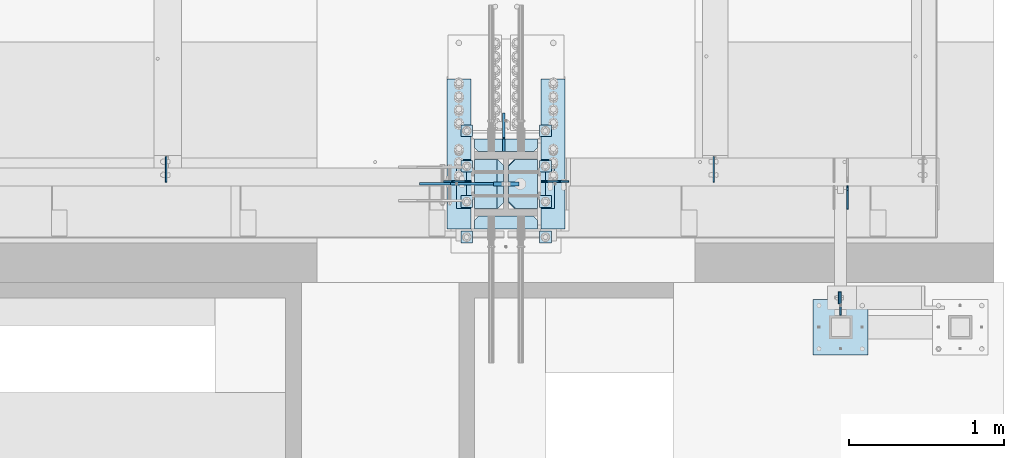
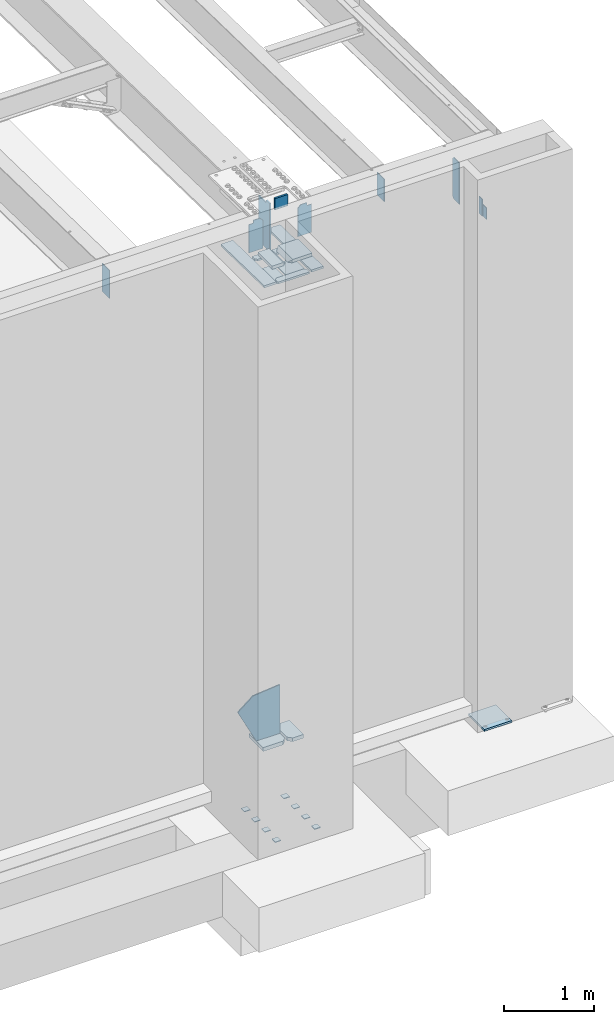
# One storey, part 1566 of 1763: 29 plates, 6 elements without a shape of their own.
"""IFC2X3 building model written with IfcOpenShell, lengths in millimetres."""

from ifc_helpers import new_model, si_unit, frame, origin_with_axes, place, context, subcontext, project, spatial, faceted_brep, material, type_object, element, aggregate, save


model = new_model("IFC2X3")

# Units and contexts
model_context = context("Model", 3, precision=1e-05, world=origin_with_axes())
body_context = subcontext(model_context, "Body", "Model", "MODEL_VIEW")
ifc_project = project(units=[si_unit("LENGTHUNIT", "METRE", prefix="MILLI"), si_unit("AREAUNIT", "SQUARE_METRE"), si_unit("VOLUMEUNIT", "CUBIC_METRE"), si_unit("MASSUNIT", "GRAM", prefix="KILO"), si_unit("TIMEUNIT", "SECOND"), si_unit("PLANEANGLEUNIT", "RADIAN"), si_unit("SOLIDANGLEUNIT", "STERADIAN"), si_unit("THERMODYNAMICTEMPERATUREUNIT", "DEGREE_CELSIUS"), si_unit("LUMINOUSINTENSITYUNIT", "LUMEN")], contexts=[model_context])

# Site, building, storey
site_placement = place(None, origin_with_axes())
site = spatial("IfcSite", under=ifc_project, at=site_placement, CompositionType="ELEMENT")
building_placement = place(site_placement, origin_with_axes())
building = spatial("IfcBuilding", under=site, at=building_placement, Name="Undefined", CompositionType="ELEMENT")
storey_placement = place(building_placement, origin_with_axes())
storey = spatial("IfcBuildingStorey", under=building, at=storey_placement, Name="Undefined", CompositionType="ELEMENT", Elevation=0.0)

# Assembly, plate
assembly_1_placement = place(storey_placement, origin_with_axes())
assembly_1 = element("IfcElementAssembly", 1, at=assembly_1_placement, inside=storey, Name="BEAM", AssemblyPlace="NOTDEFINED", PredefinedType="RIGID_FRAME")
ifc_material_1 = material(Name="STEEL/A36")
plate_type_1 = type_object("IfcPlateType", PredefinedType="NOTDEFINED")
plate_1_placement = place(assembly_1_placement, frame((-21878.3630581657, -14488.2432861204, 11817.35), z_axis=(0.0, 0.0, 1.0), x_axis=(0.0, 1.0, 0.0)))
plate_1 = element("IfcPlate", 2, at=plate_1_placement, type_object=plate_type_1, material=ifc_material_1, Name="PLATE", context=body_context, shape_type="Brep", body=[
    faceted_brep([(0.0, -4.76249999999982, 0.0), (-2.83762346953154e-10, -4.7624999996915, 228.600006103516), (-2.83762346953154e-10, 4.76250000028813, 228.600006103517), (0.0, 4.76249999999982, 0.0), (76.1999969480166, -4.76249999961874, 228.600006103516), (76.1999969480166, 4.76250000036089, 228.600006103517), (76.1999969482931, -4.76249999991705, 0.0), (76.1999969482931, 4.76250000006257, 1.81898940354586e-12)], [[[0, 1, 2, 3]], [[1, 4, 5, 2]], [[4, 6, 7, 5]], [[6, 0, 3, 7]], [[5, 7, 3, 2]], [[6, 4, 1, 0]]]),
])
aggregate(assembly_1, [plate_1])

# Assembly, plates
assembly_2_placement = place(storey_placement, origin_with_axes())
assembly_2 = element("IfcElementAssembly", 3, at=assembly_2_placement, inside=storey, Name="TEMPLATE", AssemblyPlace="NOTDEFINED", PredefinedType="RIGID_FRAME")
plate_2_placement = place(assembly_2_placement, frame((-24243.7372736984, -14020.8000000001, 3916.3625), z_axis=(-1.0, 0.0, 0.0), x_axis=(0.0, -1.0, 0.0)))
plate_2 = element("IfcPlate", 4, at=plate_2_placement, type_object=plate_type_1, material=ifc_material_1, Name="WASHER PLATE", context=body_context, shape_type="Brep", body=[
    faceted_brep([(0.0, -4.76249999999982, 0.0), (0.0, -4.76250000000073, 76.1999969482422), (0.0, 4.76250000000073, 76.1999969482422), (0.0, 4.76249999999982, 0.0), (76.1999969482422, -4.76249999999982, 76.1999969482422), (76.1999969482422, 4.76249999999982, 76.1999969482422), (76.1999969482931, -4.76249999991705, 0.0), (76.1999969482931, 4.76250000006257, 1.81898940354586e-12)], [[[0, 1, 2, 3]], [[1, 4, 5, 2]], [[4, 6, 7, 5]], [[6, 0, 3, 7]], [[5, 7, 3, 2]], [[6, 4, 1, 0]]]),
])
plate_3_placement = place(assembly_2_placement, frame((-23735.7372736984, -14020.8000000001, 3916.3625), z_axis=(-1.0, 0.0, 0.0), x_axis=(0.0, -1.0, 0.0)))
plate_3 = element("IfcPlate", 5, at=plate_3_placement, type_object=plate_type_1, material=ifc_material_1, Name="WASHER PLATE", context=body_context, shape_type="Brep", body=[
    faceted_brep([(0.0, -4.76249999999982, 0.0), (0.0, -4.76250000000073, 76.1999969482422), (0.0, 4.76250000000073, 76.1999969482422), (0.0, 4.76249999999982, 0.0), (76.1999969482422, -4.76249999999982, 76.1999969482422), (76.1999969482422, 4.76249999999982, 76.1999969482422), (76.1999969482931, -4.76249999991705, 0.0), (76.1999969482931, 4.76250000006257, 1.81898940354586e-12)], [[[0, 1, 2, 3]], [[1, 4, 5, 2]], [[4, 6, 7, 5]], [[6, 0, 3, 7]], [[5, 7, 3, 2]], [[6, 4, 1, 0]]]),
])
plate_4_placement = place(assembly_2_placement, frame((-24243.7372736984, -13792.2000000001, 3916.3625), z_axis=(-1.0, 0.0, 0.0), x_axis=(0.0, -1.0, 0.0)))
plate_4 = element("IfcPlate", 6, at=plate_4_placement, type_object=plate_type_1, material=ifc_material_1, Name="WASHER PLATE", context=body_context, shape_type="Brep", body=[
    faceted_brep([(0.0, -4.76249999999982, 0.0), (0.0, -4.76250000000073, 76.1999969482422), (0.0, 4.76250000000073, 76.1999969482422), (0.0, 4.76249999999982, 0.0), (76.1999969482422, -4.76249999999982, 76.1999969482422), (76.1999969482422, 4.76249999999982, 76.1999969482422), (76.1999969482931, -4.76249999991705, 0.0), (76.1999969482931, 4.76250000006257, 1.81898940354586e-12)], [[[0, 1, 2, 3]], [[1, 4, 5, 2]], [[4, 6, 7, 5]], [[6, 0, 3, 7]], [[5, 7, 3, 2]], [[6, 4, 1, 0]]]),
])
plate_5_placement = place(assembly_2_placement, frame((-23735.7372736984, -13792.2000000001, 3916.3625), z_axis=(-1.0, 0.0, 0.0), x_axis=(0.0, -1.0, 0.0)))
plate_5 = element("IfcPlate", 7, at=plate_5_placement, type_object=plate_type_1, material=ifc_material_1, Name="WASHER PLATE", context=body_context, shape_type="Brep", body=[
    faceted_brep([(0.0, -4.76249999999982, 0.0), (0.0, -4.76250000000073, 76.1999969482422), (0.0, 4.76250000000073, 76.1999969482422), (0.0, 4.76249999999982, 0.0), (76.1999969482422, -4.76249999999982, 76.1999969482422), (76.1999969482422, 4.76249999999982, 76.1999969482422), (76.1999969482931, -4.76249999991705, 0.0), (76.1999969482931, 4.76250000006257, 1.81898940354586e-12)], [[[0, 1, 2, 3]], [[1, 4, 5, 2]], [[4, 6, 7, 5]], [[6, 0, 3, 7]], [[5, 7, 3, 2]], [[6, 4, 1, 0]]]),
])
plate_6_placement = place(assembly_2_placement, frame((-24243.7372736984, -13563.6000000001, 3916.3625), z_axis=(-1.0, 0.0, 0.0), x_axis=(0.0, -1.0, 0.0)))
plate_6 = element("IfcPlate", 8, at=plate_6_placement, type_object=plate_type_1, material=ifc_material_1, Name="WASHER PLATE", context=body_context, shape_type="Brep", body=[
    faceted_brep([(0.0, -4.76249999999982, 0.0), (0.0, -4.76250000000073, 76.1999969482422), (0.0, 4.76250000000073, 76.1999969482422), (0.0, 4.76249999999982, 0.0), (76.1999969482422, -4.76249999999982, 76.1999969482422), (76.1999969482422, 4.76249999999982, 76.1999969482422), (76.1999969482931, -4.76249999991705, 0.0), (76.1999969482931, 4.76250000006257, 1.81898940354586e-12)], [[[0, 1, 2, 3]], [[1, 4, 5, 2]], [[4, 6, 7, 5]], [[6, 0, 3, 7]], [[5, 7, 3, 2]], [[6, 4, 1, 0]]]),
])
plate_7_placement = place(assembly_2_placement, frame((-23735.7372736984, -13563.6000000001, 3916.3625), z_axis=(-1.0, 0.0, 0.0), x_axis=(0.0, -1.0, 0.0)))
plate_7 = element("IfcPlate", 9, at=plate_7_placement, type_object=plate_type_1, material=ifc_material_1, Name="WASHER PLATE", context=body_context, shape_type="Brep", body=[
    faceted_brep([(0.0, -4.76249999999982, 0.0), (0.0, -4.76250000000073, 76.1999969482422), (0.0, 4.76250000000073, 76.1999969482422), (0.0, 4.76249999999982, 0.0), (76.1999969482422, -4.76249999999982, 76.1999969482422), (76.1999969482422, 4.76249999999982, 76.1999969482422), (76.1999969482931, -4.76249999991705, 0.0), (76.1999969482931, 4.76250000006257, 1.81898940354586e-12)], [[[0, 1, 2, 3]], [[1, 4, 5, 2]], [[4, 6, 7, 5]], [[6, 0, 3, 7]], [[5, 7, 3, 2]], [[6, 4, 1, 0]]]),
])
plate_8_placement = place(assembly_2_placement, frame((-24243.7372736984, -13335.0000000001, 3916.3625), z_axis=(-1.0, 0.0, 0.0), x_axis=(0.0, -1.0, 0.0)))
plate_8 = element("IfcPlate", 10, at=plate_8_placement, type_object=plate_type_1, material=ifc_material_1, Name="WASHER PLATE", context=body_context, shape_type="Brep", body=[
    faceted_brep([(0.0, -4.76249999999982, 0.0), (0.0, -4.76250000000073, 76.1999969482422), (0.0, 4.76250000000073, 76.1999969482422), (0.0, 4.76249999999982, 0.0), (76.1999969482422, -4.76249999999982, 76.1999969482422), (76.1999969482422, 4.76249999999982, 76.1999969482422), (76.1999969482931, -4.76249999991705, 0.0), (76.1999969482931, 4.76250000006257, 1.81898940354586e-12)], [[[0, 1, 2, 3]], [[1, 4, 5, 2]], [[4, 6, 7, 5]], [[6, 0, 3, 7]], [[5, 7, 3, 2]], [[6, 4, 1, 0]]]),
])
plate_9_placement = place(assembly_2_placement, frame((-23735.7372736984, -13335.0000000001, 3916.3625), z_axis=(-1.0, 0.0, 0.0), x_axis=(0.0, -1.0, 0.0)))
plate_9 = element("IfcPlate", 11, at=plate_9_placement, type_object=plate_type_1, material=ifc_material_1, Name="WASHER PLATE", context=body_context, shape_type="Brep", body=[
    faceted_brep([(0.0, -4.76249999999982, 0.0), (0.0, -4.76250000000073, 76.1999969482422), (0.0, 4.76250000000073, 76.1999969482422), (0.0, 4.76249999999982, 0.0), (76.1999969482422, -4.76249999999982, 76.1999969482422), (76.1999969482422, 4.76249999999982, 76.1999969482422), (76.1999969482931, -4.76249999991705, 0.0), (76.1999969482931, 4.76250000006257, 1.81898940354586e-12)], [[[0, 1, 2, 3]], [[1, 4, 5, 2]], [[4, 6, 7, 5]], [[6, 0, 3, 7]], [[5, 7, 3, 2]], [[6, 4, 1, 0]]]),
])
aggregate(assembly_2, [plate_2, plate_3, plate_4, plate_5, plate_6, plate_7, plate_8, plate_9])

# Assembly, plate
assembly_3_placement = place(storey_placement, origin_with_axes())
assembly_3 = element("IfcElementAssembly", 12, at=assembly_3_placement, inside=storey, Name="FRAME", AssemblyPlace="NOTDEFINED", PredefinedType="RIGID_FRAME")
plate_type_2 = type_object("IfcPlateType", PredefinedType="NOTDEFINED")
plate_10_placement = place(assembly_3_placement, frame((-21868.8380596657, -14412.0432891246, 11969.7500061035), z_axis=(0.0, 0.0, -1.0), x_axis=(0.0, -1.0, 0.0)))
plate_10 = element("IfcPlate", 13, at=plate_10_placement, type_object=plate_type_2, material=ifc_material_1, Name="PLATE", context=body_context, shape_type="Brep", body=[
    faceted_brep([(0.0, -4.76249999999982, 0.0), (-3.05175672110636e-06, -4.7625000002663, 152.399993896484), (-3.05175490211695e-06, 4.76249999972788, 152.399993896484), (0.0, 4.76249999999982, 0.0), (152.400009155272, -4.76249999975698, 152.399993896484), (152.400009155273, 4.76250000024447, 152.399993896484), (152.400009155272, -4.76249999948777, 5.45696821063757e-12), (152.400009155273, 4.76250000051368, 3.63797880709171e-12)], [[[0, 1, 2, 3]], [[1, 4, 5, 2]], [[4, 6, 7, 5]], [[6, 0, 3, 7]], [[5, 7, 3, 2]], [[6, 4, 1, 0]]]),
])

assembly_4_placement = place(storey_placement, origin_with_axes())
assembly_4 = element("IfcElementAssembly", 14, at=assembly_4_placement, inside=storey, Name="BEAM", AssemblyPlace="NOTDEFINED", PredefinedType="RIGID_FRAME")
plate_11_placement = place(assembly_4_placement, frame((-21824.388056465, -13880.3060686171, 11590.3375), z_axis=(0.0, 0.0, 1.0), x_axis=(0.0, 1.0, 0.0)))
plate_11 = element("IfcPlate", 15, at=plate_11_placement, type_object=plate_type_2, material=ifc_material_1, Name="PLATE", context=body_context, shape_type="Brep", body=[
    faceted_brep([(0.0, -4.76249999999982, 0.0), (0.0, -4.76250000012806, 568.325012206604), (0.0, 4.7624999999025, 568.325012206606), (0.0, 4.76249999999982, 0.0), (120.649993896484, -4.76250000000073, 568.325012207031), (120.649993896484, 4.76250000000073, 568.325012207031), (152.399993896484, -4.76250000000073, 536.575012207031), (152.399993896484, 4.76250000000073, 536.575012207031), (152.399993896484, -4.76250000000073, 31.75), (152.399993896484, 4.76250000000073, 31.75), (120.650001525879, -4.76249999999709, 0.0), (120.650001525879, 4.76249999999709, 0.0)], [[[0, 1, 2, 3]], [[1, 4, 5, 2]], [[4, 6, 7, 5]], [[6, 8, 9, 7]], [[8, 10, 11, 9]], [[10, 0, 3, 11]], [[5, 7, 9, 11, 3, 2]], [[10, 8, 6, 4, 1, 0]]]),
])

# Plate
plate_type_3 = type_object("IfcPlateType", PredefinedType="NOTDEFINED")
plate_12_placement = place(assembly_3_placement, frame((-22046.638056465, -14462.8432982799, 5080.0), z_axis=(1.0, 0.0, 0.0), x_axis=(0.0, -1.0, 0.0)))
plate_12 = element("IfcPlate", 16, at=plate_12_placement, type_object=plate_type_3, material=ifc_material_1, Name="PLATE", context=body_context, shape_type="Brep", body=[
    faceted_brep([(0.0, -12.6999999999971, -1.81898940354586e-12), (0.0, -12.6999999999998, 355.600006103516), (0.0, 12.6999999999998, 355.600006103516), (0.0, 12.6999999999971, -1.81898940354586e-12), (355.600006103516, -12.6999999999998, 355.600006103516), (355.600006103516, 12.6999999999998, 355.600006103516), (355.600006103516, -12.6999999999998, 0.0), (355.600006103516, 12.6999999999998, 0.0)], [[[0, 1, 2, 3]], [[1, 4, 5, 2]], [[4, 6, 7, 5]], [[6, 0, 3, 7]], [[5, 7, 3, 2]], [[6, 4, 1, 0]]]),
])

aggregate(assembly_3, [plate_10, plate_12])

# Assembly, plates
assembly_5_placement = place(storey_placement, origin_with_axes())
assembly_5 = element("IfcElementAssembly", 17, at=assembly_5_placement, inside=storey, Name="COLUMN", AssemblyPlace="NOTDEFINED", PredefinedType="RIGID_FRAME")
ifc_material_2 = material(Name="STEEL/A572-50")
plate_type_4 = type_object("IfcPlateType", PredefinedType="NOTDEFINED")
plate_13_placement = place(assembly_5_placement, frame((-23945.2872721785, -13715.9998186171, 12375.8598653502), z_axis=(0.0, 0.0, -1.0), x_axis=(-1.0, 0.0, 0.0)))
plate_13 = element("IfcPlate", 18, at=plate_13_placement, type_object=plate_type_4, material=ifc_material_2, Name="PLATE", context=body_context, shape_type="Brep", body=[
    faceted_brep([(0.0, 12.7, 152.399990844726), (-1.45519152283669e-11, 7.27595761418343e-12, 165.099990844727), (165.099990844727, 0.0, 165.099990844727), (165.099990844727, 12.7, 152.399990844726), (0.0, -12.7, 152.399990844726), (165.099990844727, -12.7, 152.399990844726), (0.0, 12.6999999999971, -1.81898940354586e-12), (0.0, -12.6999999999971, -1.81898940354586e-12), (165.099990844727, -12.7, 0.0), (165.099990844727, 12.7, 0.0)], [[[0, 1, 2, 3]], [[1, 4, 5, 2]], [[6, 7, 4, 1, 0]], [[5, 8, 9, 3, 2]], [[8, 7, 6, 9]], [[9, 6, 0, 3]], [[7, 8, 5, 4]]]),
])
plate_type_5 = type_object("IfcPlateType", PredefinedType="NOTDEFINED")
plate_14_placement = place(assembly_5_placement, frame((-24231.0372736984, -13874.7498293513, 11566.5250034926), z_axis=(0.0, 1.0, 0.0), x_axis=(1.0, 0.0, 0.0)))
plate_14 = element("IfcPlate", 19, at=plate_14_placement, type_object=plate_type_5, material=ifc_material_2, Name="PLATE", context=body_context, shape_type="Brep", body=[
    faceted_brep([(150.018745422363, 22.2249999999985, -1.45519152283669e-11), (188.118743896484, 22.2250000000222, 38.0999984741065), (150.018745422363, -15.8750547711388, 1.09139364212751e-11), (0.0, -22.2250000000022, 1.45519152283669e-11), (0.0, 22.2249999999985, -1.45519152283669e-11), (143.668767038595, -22.2250000000022, 1.45519152283669e-11), (0.0, -22.2249999997875, 317.500000000015), (143.668774023809, -22.2249999997875, 317.500000000015), (150.018745422363, 22.2250000002114, 317.499999999985), (0.0, 22.2250000002114, 317.499999999985), (150.018745422363, -15.8750617561036, 317.500000000011), (188.118743896484, 22.2250000001877, 279.400001525864)], [[[0, 1, 2]], [[3, 4, 0, 2, 5]], [[6, 3, 5, 7]], [[8, 9, 6, 7, 10]], [[8, 10, 11]], [[7, 5, 2, 1, 11, 10]], [[0, 4, 9, 8, 11, 1]], [[3, 6, 9, 4]]]),
])
plate_type_6 = type_object("IfcPlateType", PredefinedType="NOTDEFINED")
plate_15_placement = place(assembly_5_placement, frame((-24012.7560236984, -13874.7498293513, 11566.5250034926), z_axis=(0.0, 1.0, 0.0), x_axis=(1.0, 0.0, 0.0)))
plate_15 = element("IfcPlate", 20, at=plate_15_placement, type_object=plate_type_6, material=ifc_material_2, Name="PLATE", context=body_context, shape_type="Brep", body=[
    faceted_brep([(38.0999984741211, 22.2249999999985, -1.45519152283669e-11), (38.0999984741211, -15.8749712831541, 1.09139364212751e-11), (0.0, 22.2250000000222, 38.0999984741065), (296.068756103516, 22.2249999999985, -1.45519152283669e-11), (296.068756103516, -22.2250000000022, 1.45519152283669e-11), (44.4500271909674, -22.2250000000022, 1.45519152283669e-11), (296.068756103516, -22.2249999997875, 317.500000000015), (44.4500202057534, -22.2249999997875, 317.500000000015), (38.0999984741211, 22.2250000002114, 317.499999999985), (0.0, 22.2250000001877, 279.400001525864), (38.0999984741211, -15.8749782681552, 317.500000000011), (296.068756103516, 22.2250000002114, 317.499999999985)], [[[0, 1, 2]], [[0, 3, 4, 5, 1]], [[4, 6, 7, 5]], [[8, 9, 10]], [[6, 11, 8, 10, 7]], [[9, 2, 1, 5, 7, 10]], [[8, 11, 3, 0, 2, 9]], [[6, 4, 3, 11]]]),
])
plate_type_7 = type_object("IfcPlateType", PredefinedType="NOTDEFINED")
plate_16_placement = place(assembly_5_placement, frame((-24346.9247736984, -13874.749972618, 5054.60000349261), z_axis=(0.0, 1.0, 0.0), x_axis=(1.0, 0.0, 0.0)))
plate_16 = element("IfcPlate", 21, at=plate_16_placement, type_object=plate_type_7, material=ifc_material_1, Name="PLATE", context=body_context, shape_type="Brep", body=[
    faceted_brep([(0.0, -25.4000000000015, 0.0), (0.0, -25.4000000000751, 317.500000000018), (0.0, 25.3999999999251, 317.499999999984), (0.0, 25.4000000000015, 0.0), (257.968757629395, -25.4000000000751, 317.500000000018), (257.968757629395, 25.3999999999251, 317.499999999984), (304.006256103516, -25.4000000000642, 271.462501525897), (304.006256103516, 25.399999999936, 271.462501525863), (304.006256103516, -25.4000000000115, 46.0374984741393), (304.006256103516, 25.3999999999878, 46.0374984741047), (257.968757629395, -25.4000000000005, 1.81898940354586e-11), (257.968757629395, 25.3999999999987, -1.63709046319127e-11)], [[[0, 1, 2, 3]], [[1, 4, 5, 2]], [[4, 6, 7, 5]], [[6, 8, 9, 7]], [[8, 10, 11, 9]], [[10, 0, 3, 11]], [[5, 7, 9, 11, 3, 2]], [[10, 8, 6, 4, 1, 0]]]),
])
plate_type_8 = type_object("IfcPlateType", PredefinedType="NOTDEFINED")
plate_17_placement = place(assembly_5_placement, frame((-24012.7560236984, -13874.749972618, 5054.60000349261), z_axis=(0.0, 1.0, 0.0), x_axis=(1.0, 0.0, 0.0)))
plate_17 = element("IfcPlate", 22, at=plate_17_placement, type_object=plate_type_8, material=ifc_material_1, Name="PLATE", context=body_context, shape_type="Brep", body=[
    faceted_brep([(0.0, -25.4000000000115, 46.0374984741393), (0.0, -25.4000000000642, 271.462501525897), (0.0, 25.399999999936, 271.462501525863), (0.0, 25.3999999999878, 46.0374984741047), (46.0374984741211, -25.4000000000751, 317.500000000018), (46.0374984741211, 25.3999999999251, 317.499999999984), (188.118743896484, -25.4000000000751, 317.500000000018), (188.118743896484, 25.3999999999251, 317.499999999984), (188.118743896484, -25.4000000000005, 1.81898940354586e-11), (188.118743896484, 25.3999999999987, -1.63709046319127e-11), (46.0374984741211, -25.4000000000005, 1.81898940354586e-11), (46.0374984741211, 25.3999999999987, -1.63709046319127e-11)], [[[0, 1, 2, 3]], [[1, 4, 5, 2]], [[4, 6, 7, 5]], [[6, 8, 9, 7]], [[8, 10, 11, 9]], [[10, 0, 3, 11]], [[5, 7, 9, 11, 3, 2]], [[10, 8, 6, 4, 1, 0]]]),
])
ifc_material_3 = material(Name="STEEL/A572-GR.50")
plate_type_9 = type_object("IfcPlateType", PredefinedType="NOTDEFINED")
plate_18_placement = place(assembly_5_placement, frame((-24042.9185236223, -13715.9999990896, 5080.0), z_axis=(-1.0, 0.0, 0.0), x_axis=(0.0, 0.0, 1.0)))
plate_18 = element("IfcPlate", 23, at=plate_18_placement, type_object=plate_type_9, material=ifc_material_3, Name="PLATE", context=body_context, shape_type="Brep", body=[
    faceted_brep([(-7.27595761418343e-12, -7.9375, 0.0), (-1.96450855582952e-10, -7.9375, 304.799987792954), (-1.96450855582952e-10, 7.9375, 304.799987792954), (-7.27595761418343e-12, 7.9375, 0.0), (467.916351318356, -7.93750000005821, 542.637756347671), (467.916351318363, 7.93749999994179, 542.637756347649), (626.727233886716, -7.93749999988177, 344.407836914084), (626.727233886722, 7.93750000011823, 344.407836914059), (660.400024414061, -7.93749999969259, 1.81898940354586e-11), (660.400024414067, 7.93750000030741, -3.63797880709171e-12)], [[[0, 1, 2, 3]], [[1, 4, 5, 2]], [[4, 6, 7, 5]], [[6, 8, 9, 7]], [[8, 0, 3, 9]], [[5, 7, 9, 3, 2]], [[8, 6, 4, 1, 0]]]),
])
plate_type_10 = type_object("IfcPlateType", PredefinedType="NOTDEFINED")
plate_19_placement = place(assembly_5_placement, frame((-24043.7122736984, -13508.0373164194, 12153.8208949172), z_axis=(0.0, 1.0, 0.0), x_axis=(0.0, 0.0, -1.0)))
plate_19 = element("IfcPlate", 24, at=plate_19_placement, type_object=plate_type_10, material=ifc_material_2, Name="PLATE", context=body_context, shape_type="Brep", body=[
    faceted_brep([(652.461860656904, -7.9375, 250.824996880596), (652.461861279093, -7.9375, 95.2500331813098), (652.461861279093, 7.9375, 95.2500331813098), (652.461860656904, 7.9375, 250.824996947802), (653.428591221118, -7.9375, 90.3899536671306), (653.428591221118, 7.9375, 90.3899536671306), (656.181605138074, -7.9375, 86.2697772099873), (656.181605138074, 7.9375, 86.2697772099873), (660.301781617236, -7.9375, 83.5167633259862), (660.301781617236, 7.9375, 83.5167633259862), (665.16186113915, -7.9375, 82.5500334228345), (665.16186113915, 7.9375, 82.5500334228345), (701.674986078371, -7.9375, 82.5500335688612), (701.674987793023, 7.9375, 82.5500335688612), (36.5118331910835, -7.9375, 250.824996039873), (36.5118331910835, 7.9375, 250.824996948217), (36.5118305464439, 7.9375, 95.2500632755091), (36.5118305464439, -7.9375, 95.2500632755091), (35.5451005412397, 7.9375, 90.3899837738973), (35.5451005412397, -7.9375, 90.3899837738973), (32.7920865707219, 7.9375, 86.2698073525426), (32.7920865707219, -7.9375, 86.2698073525426), (28.6719100557711, 7.9375, 83.5167935221034), (28.6719100557711, -7.9375, 83.5167935221034), (23.8118305212902, 7.9375, 82.5500636821344), (23.8118305212902, -7.9375, 82.5500636821344), (5.27506927028298e-11, 7.9375, 82.5500640869141), (5.27506927028298e-11, -7.9375, 82.5500640869141), (-7.27595761418343e-12, 7.9375, 0.0), (-7.27595761418343e-12, -7.9375, 0.0), (701.674987792967, -7.9375, -4.74756234325469e-10), (701.674987792967, 7.9375, -4.74756234325469e-10)], [[[0, 1, 2, 3]], [[4, 5, 2, 1]], [[6, 7, 5, 4]], [[8, 9, 7, 6]], [[10, 11, 9, 8]], [[12, 13, 11, 10]], [[14, 15, 16, 17]], [[17, 16, 18, 19]], [[19, 18, 20, 21]], [[21, 20, 22, 23]], [[23, 22, 24, 25]], [[25, 24, 26, 27]], [[28, 29, 27, 26]], [[30, 29, 28, 31]], [[8, 6, 4, 1, 0, 14, 17, 19, 21, 23, 25, 27, 29, 30, 12, 10]], [[15, 14, 0, 3]], [[31, 28, 26, 24, 22, 20, 18, 16, 15, 3, 2, 5, 7, 9, 11, 13]], [[30, 31, 13, 12]]]),
])
plate_type_11 = type_object("IfcPlateType", PredefinedType="NOTDEFINED")
plate_20_placement = place(assembly_5_placement, frame((-24231.0372681234, -13508.0373327294, 11438.1830739405), z_axis=(1.0, 0.0, 0.0), x_axis=(0.0, 1.0, 0.0)))
plate_20 = element("IfcPlate", 25, at=plate_20_placement, type_object=plate_type_11, material=ifc_material_2, Name="PLATE", context=body_context, shape_type="Brep", body=[
    faceted_brep([(-2.63229335373174e-12, -12.7, 25.3999996185303), (-4.02906152885407e-09, -12.6999999999989, 380.999994277954), (-4.04725142288953e-09, 12.7000000000025, 380.999994277954), (-2.78305378742516e-10, 12.7000000000025, 25.3999996185303), (25.399999614232, -12.6999999999825, 406.399993896484), (25.3999996142138, 12.7000000000189, 406.399993896484), (82.5500030517669, -12.6999999999425, 406.399993896484), (82.5500030517469, 12.7000000000571, 406.399993896484), (82.5500030517669, -12.6999999999425, -4.36557456851006e-11), (82.5500030517469, 12.7000000000571, -4.36557456851006e-11), (25.3999996185303, -12.7, 0.0), (25.3999996185194, 12.7000000000189, -1.45519152283669e-11)], [[[0, 1, 2, 3]], [[1, 4, 5, 2]], [[4, 6, 7, 5]], [[6, 8, 9, 7]], [[8, 10, 11, 9]], [[10, 0, 3, 11]], [[5, 7, 9, 11, 3, 2]], [[10, 8, 6, 4, 1, 0]]]),
])
plate_21_placement = place(assembly_5_placement, frame((-24231.0372681234, -13923.9623312835, 11438.1830739405), z_axis=(1.0, 0.0, 0.0), x_axis=(0.0, -1.0, 0.0)))
plate_21 = element("IfcPlate", 26, at=plate_21_placement, type_object=plate_type_11, material=ifc_material_2, Name="PLATE", context=body_context, shape_type="Brep", body=[
    faceted_brep([(-2.63229335373174e-12, -12.7, 25.3999996185303), (-4.02906152885407e-09, -12.6999999999989, 380.999994277954), (-4.04725142288953e-09, 12.7000000000025, 380.999994277954), (-2.78305378742516e-10, 12.7000000000025, 25.3999996185303), (25.399999614232, -12.6999999999825, 406.399993896484), (25.3999996142138, 12.7000000000189, 406.399993896484), (82.5500030517669, -12.6999999999425, 406.399993896484), (82.5500030517469, 12.7000000000571, 406.399993896484), (82.5500030517669, -12.6999999999425, -4.36557456851006e-11), (82.5500030517469, 12.7000000000571, -4.36557456851006e-11), (25.3999996185303, -12.7, 0.0), (25.3999996185194, 12.7000000000189, -1.45519152283669e-11)], [[[0, 1, 2, 3]], [[1, 4, 5, 2]], [[4, 6, 7, 5]], [[6, 8, 9, 7]], [[8, 10, 11, 9]], [[10, 0, 3, 11]], [[5, 7, 9, 11, 3, 2]], [[10, 8, 6, 4, 1, 0]]]),
])
plate_type_12 = type_object("IfcPlateType", PredefinedType="NOTDEFINED")
plate_22_placement = place(assembly_5_placement, frame((-24253.2622732509, -13699.3310686168, 12158.6625004447), z_axis=(-1.0, 0.0, 0.0), x_axis=(0.0, 0.0, -1.0)))
plate_22 = element("IfcPlate", 27, at=plate_22_placement, type_object=plate_type_12, material=ifc_material_3, Name="PLATE", context=body_context, shape_type="Brep", body=[
    faceted_brep([(38.0999984741193, -4.76250000000073, -2.66707502305508e-07), (0.0, -4.76249999999709, 38.1000000000004), (0.0, 4.76249999999709, 38.1000000000004), (38.0999984741193, 4.76250000000073, 2.5465851649642e-11), (26.9875001903692, -4.76250000000073, 117.47502130835), (26.9875001903692, 4.76250000000073, 117.47502130835), (0.0, 4.76250000013351, 117.474999999919), (0.0, -4.76249999983884, 117.474999999904), (31.8475797103492, -4.76250000000073, 118.441751221213), (31.8475797103492, 4.76250000000073, 118.441751221213), (35.9677561840108, -4.76250000000073, 121.194765113451), (35.9677561840108, 4.76250000000073, 121.194765113451), (38.7207700927302, -4.76250000000073, 125.314941576096), (38.7207700927302, 4.76250000000073, 125.314941576096), (39.6875000250402, -4.76250000000073, 130.175021092207), (39.6875000250402, 4.76250000000073, 130.175021092207), (39.6875001203061, -4.76250000000073, 177.800003341534), (39.6875001203061, 4.76250000000073, 177.799987792991), (423.862487792872, -4.76250000000073, 177.799987793198), (423.862487792872, 4.76250000000073, 177.799987793198), (423.862487792967, -4.76250000000073, 2.3283064365387e-10), (423.862487792967, 4.76250000000073, 2.3283064365387e-10)], [[[0, 1, 2, 3]], [[4, 5, 6, 7]], [[8, 9, 5, 4]], [[10, 11, 9, 8]], [[12, 13, 11, 10]], [[14, 15, 13, 12]], [[16, 17, 15, 14]], [[18, 19, 17, 16]], [[18, 20, 21, 19]], [[21, 20, 0, 3]], [[6, 5, 9, 11, 13, 15, 17, 19, 21, 3, 2]], [[7, 6, 2, 1]], [[20, 18, 16, 14, 12, 10, 8, 4, 7, 1, 0]]]),
])
plate_23_placement = place(assembly_5_placement, frame((-23802.4122732509, -13699.3310686168, 12158.6624995558), z_axis=(1.0, 0.0, 0.0), x_axis=(0.0, 0.0, -1.0)))
plate_23 = element("IfcPlate", 28, at=plate_23_placement, type_object=plate_type_12, material=ifc_material_3, Name="PLATE", context=body_context, shape_type="Brep", body=[
    faceted_brep([(26.9875001903692, -4.76250000000073, 117.47502130835), (26.9875001903692, 4.76250000000073, 117.47502130835), (0.0, 4.76250000013351, 117.474999999919), (0.0, -4.76249999983884, 117.474999999904), (31.8475797103492, -4.76250000000073, 118.441751221213), (31.8475797103492, 4.76250000000073, 118.441751221213), (35.9677561840108, -4.76250000000073, 121.194765113451), (35.9677561840108, 4.76250000000073, 121.194765113451), (38.7207700927302, -4.76250000000073, 125.314941576096), (38.7207700927302, 4.76250000000073, 125.314941576096), (39.6875000250402, -4.76250000000073, 130.175021092207), (39.6875000250402, 4.76250000000073, 130.175021092207), (39.6875001203061, -4.76250000000073, 177.800003341534), (39.6875001203061, 4.76250000000073, 177.799987792991), (38.0999984741193, -4.76250000000073, -2.66707502305508e-07), (0.0, -4.76249999999709, 38.1000000000004), (0.0, 4.76249999999709, 38.1000000000004), (38.0999984741193, 4.76250000000073, 2.5465851649642e-11), (423.862487792967, 4.76250000000073, 2.3283064365387e-10), (423.862487792967, -4.76250000000073, 2.3283064365387e-10), (423.862487792872, -4.76250000000073, 177.799987793198), (423.862487792872, 4.76250000000073, 177.799987793198)], [[[0, 1, 2, 3]], [[4, 5, 1, 0]], [[6, 7, 5, 4]], [[8, 9, 7, 6]], [[10, 11, 9, 8]], [[12, 13, 11, 10]], [[14, 15, 16, 17]], [[18, 19, 14, 17]], [[20, 19, 18, 21]], [[19, 20, 12, 10, 8, 6, 4, 0, 3, 15, 14]], [[3, 2, 16, 15]], [[2, 1, 5, 7, 9, 11, 13, 21, 18, 17, 16]], [[20, 21, 13, 12]]]),
])
plate_type_13 = type_object("IfcPlateType", PredefinedType="NOTDEFINED")
plate_24_placement = place(assembly_5_placement, frame((-23646.8372737834, -13037.9263617301, 11429.9455920529), z_axis=(0.0, -0.999781542838788, 0.0209013539966307), x_axis=(-1.0, 0.0, 0.0)))
plate_24 = element("IfcPlate", 29, at=plate_24_placement, type_object=plate_type_13, material=ifc_material_2, Name="PLATE", context=body_context, shape_type="Brep", body=[
    faceted_brep([(0.0, -14.2875000000058, 0.0), (-5.78584149479866e-08, -14.2875000003296, 968.498901367962), (-5.78475010115653e-08, 14.2874999996911, 968.498901367973), (0.0, 14.2875000000058, 0.0), (155.574996949199, -14.2875000002678, 968.498901367961), (155.57499694921, 14.2874999997548, 968.498901367971), (155.574996948242, -14.2874999999494, -2.16459739021957e-10), (155.574996948249, 14.2875000000731, -2.07364792004228e-10)], [[[0, 1, 2, 3]], [[1, 4, 5, 2]], [[4, 6, 7, 5]], [[6, 0, 3, 7]], [[5, 7, 3, 2]], [[6, 4, 1, 0]]]),
])
plate_25_placement = place(assembly_5_placement, frame((-24253.2622676279, -13037.9263617297, 11429.9455920529), z_axis=(0.0, -0.999781542838788, 0.0209013539966307), x_axis=(-1.0, 0.0, 0.0)))
plate_25 = element("IfcPlate", 30, at=plate_25_placement, type_object=plate_type_13, material=ifc_material_2, Name="PLATE", context=body_context, shape_type="Brep", body=[
    faceted_brep([(0.0, -14.2875000000058, 0.0), (-5.78584149479866e-08, -14.2875000003296, 968.498901367962), (-5.78475010115653e-08, 14.2874999996911, 968.498901367973), (0.0, 14.2875000000058, 0.0), (155.574996949199, -14.2875000002678, 968.498901367961), (155.57499694921, 14.2874999997548, 968.498901367971), (155.574996948242, -14.2874999999494, -2.16459739021957e-10), (155.574996948249, 14.2875000000731, -2.07364792004228e-10)], [[[0, 1, 2, 3]], [[1, 4, 5, 2]], [[4, 6, 7, 5]], [[6, 0, 3, 7]], [[5, 7, 3, 2]], [[6, 4, 1, 0]]]),
])
plate_type_14 = type_object("IfcPlateType", PredefinedType="NOTDEFINED")
plate_26_placement = place(assembly_5_placement, frame((-24281.8372736984, -13874.7498343054, 11341.3455931888), z_axis=(0.0, 1.0, 0.0), x_axis=(1.0, 0.0, 0.0)))
plate_26 = element("IfcPlate", 31, at=plate_26_placement, type_object=plate_type_14, material=ifc_material_2, Name="PLATE", context=body_context, shape_type="Brep", body=[
    faceted_brep([(-7.27595761418343e-12, -7.9375, 0.0), (0.0, -7.9375, 317.5), (0.0, 7.9375, 317.5), (-7.27595761418343e-12, 7.9375, 0.0), (200.818748474121, -7.937499999789, 317.500000000005), (200.818748474121, 7.937500000211, 317.499999999995), (238.918746948242, -7.93749999981264, 279.400001525884), (238.918746948242, 7.93750000018736, 279.400001525873), (238.918746948242, -7.93749999997635, 38.0999984741266), (238.918746948242, 7.93750000002365, 38.0999984741156), (200.818748474121, -7.93750000000182, 5.45696821063757e-12), (200.818748474121, 7.93749999999818, -5.45696821063757e-12)], [[[0, 1, 2, 3]], [[1, 4, 5, 2]], [[4, 6, 7, 5]], [[6, 8, 9, 7]], [[8, 10, 11, 9]], [[10, 0, 3, 11]], [[5, 7, 9, 11, 3, 2]], [[10, 8, 6, 4, 1, 0]]]),
])
plate_27_placement = place(assembly_5_placement, frame((-24012.7560236984, -13874.7498343054, 11341.3455931888), z_axis=(0.0, 1.0, 0.0), x_axis=(1.0, 0.0, 0.0)))
plate_27 = element("IfcPlate", 32, at=plate_27_placement, type_object=plate_type_14, material=ifc_material_2, Name="PLATE", context=body_context, shape_type="Brep", body=[
    faceted_brep([(0.0, -7.9375, 38.0999984741211), (0.0, -7.9375, 279.400001525879), (0.0, 7.9375, 279.400001525879), (0.0, 7.9375, 38.0999984741211), (38.0999984741211, -7.9375, 317.5), (38.0999984741211, 7.9375, 317.5), (238.918746948242, -7.937499999789, 317.500000000005), (238.918746948242, 7.937500000211, 317.499999999995), (238.918746948242, -7.93750000000182, 5.45696821063757e-12), (238.918746948242, 7.93749999999818, -5.45696821063757e-12), (38.0999984741211, -7.9375, 0.0), (38.0999984741211, 7.9375, 0.0)], [[[0, 1, 2, 3]], [[1, 4, 5, 2]], [[4, 6, 7, 5]], [[6, 8, 9, 7]], [[8, 10, 11, 9]], [[10, 0, 3, 11]], [[5, 7, 9, 11, 3, 2]], [[10, 8, 6, 4, 1, 0]]]),
])
aggregate(assembly_5, [plate_14, plate_15, plate_16, plate_17, plate_18, plate_13, plate_24, plate_25, plate_26, plate_27, plate_22, plate_23, plate_20, plate_21, plate_19])

# Assembly, plate
assembly_6_placement = place(storey_placement, origin_with_axes())
assembly_6 = element("IfcElementAssembly", 33, at=assembly_6_placement, inside=storey, Name="BEAM", AssemblyPlace="NOTDEFINED", PredefinedType="RIGID_FRAME")
plate_type_15 = type_object("IfcPlateType", PredefinedType="NOTDEFINED")
plate_28_placement = place(assembly_6_placement, frame((-26221.7622736983, -13704.0935686171, 12127.1640902963), z_axis=(0.0, 1.0, 0.0), x_axis=(0.0, 0.0, -1.0)))
plate_28 = element("IfcPlate", 34, at=plate_28_placement, type_object=plate_type_15, material=ifc_material_1, Name="PLATE", context=body_context, shape_type="Brep", body=[
    faceted_brep([(0.0, -4.76249999999982, 0.0), (0.0, -4.76250000000073, 165.100006103516), (0.0, 4.76250000000073, 165.100006103516), (0.0, 4.76249999999982, 0.0), (381.0, -4.76250000000073, 165.100006103516), (381.0, 4.76250000000073, 165.100006103516), (381.0, -4.76250000000073, 0.0), (381.0, 4.76250000000073, 0.0)], [[[0, 1, 2, 3]], [[1, 4, 5, 2]], [[4, 6, 7, 5]], [[6, 0, 3, 7]], [[5, 7, 3, 2]], [[6, 4, 1, 0]]]),
])
aggregate(assembly_6, [plate_28])

# Plate
plate_type_16 = type_object("IfcPlateType", PredefinedType="NOTDEFINED")
plate_29_placement = place(assembly_4_placement, frame((-22687.1937736984, -13704.0935686171, 12127.1640902963), z_axis=(0.0, 1.0, 0.0), x_axis=(0.0, 0.0, -1.0)))
plate_29 = element("IfcPlate", 35, at=plate_29_placement, type_object=plate_type_16, material=ifc_material_1, Name="PLATE", context=body_context, shape_type="Brep", body=[
    faceted_brep([(0.0, -3.96900000000096, 0.0), (0.0, -3.96900000000096, 165.100006103516), (0.0, 3.96900000000096, 165.100006103516), (0.0, 3.96900000000096, 0.0), (304.799987792969, -3.96900000000096, 165.100006103516), (304.799987792969, 3.96900000000096, 165.100006103516), (304.799987792969, -3.96900000000096, -3.63797880709171e-11), (304.799987792969, 3.96900000000096, -3.63797880709171e-11)], [[[0, 1, 2, 3]], [[1, 4, 5, 2]], [[4, 6, 7, 5]], [[6, 0, 3, 7]], [[5, 7, 3, 2]], [[6, 4, 1, 0]]]),
])

aggregate(assembly_4, [plate_11, plate_29])

save(model, "model.ifc")
